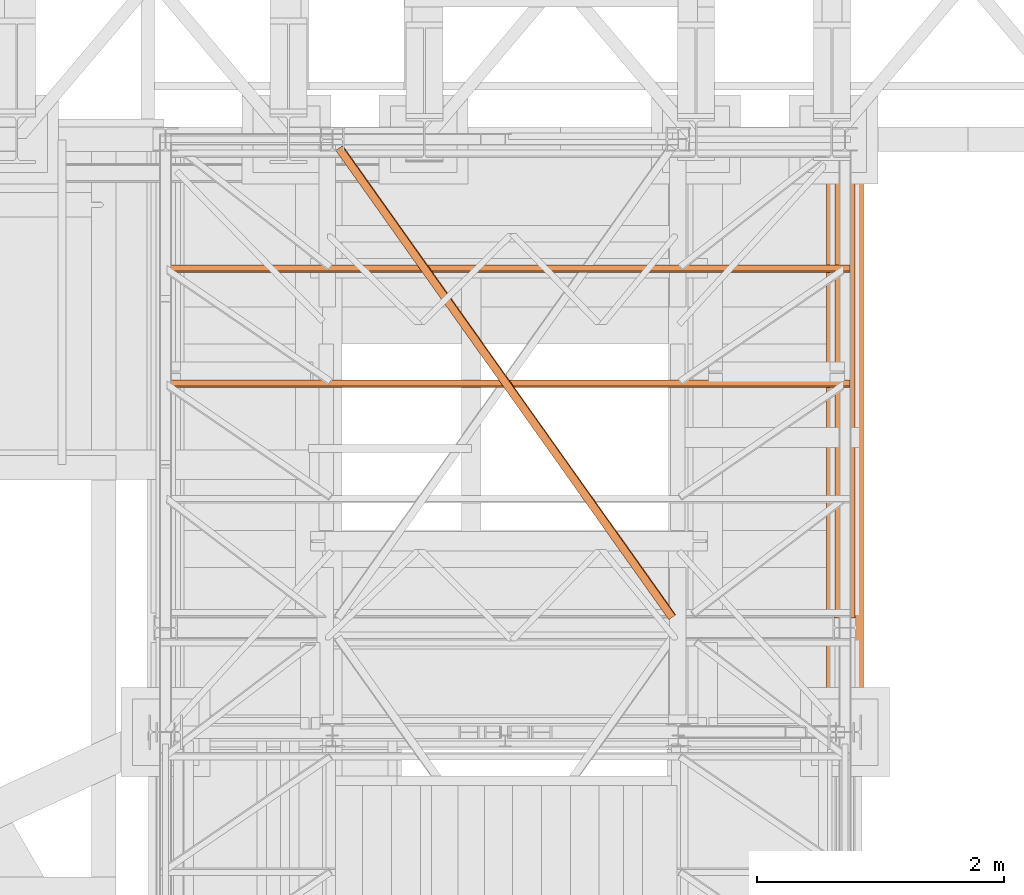
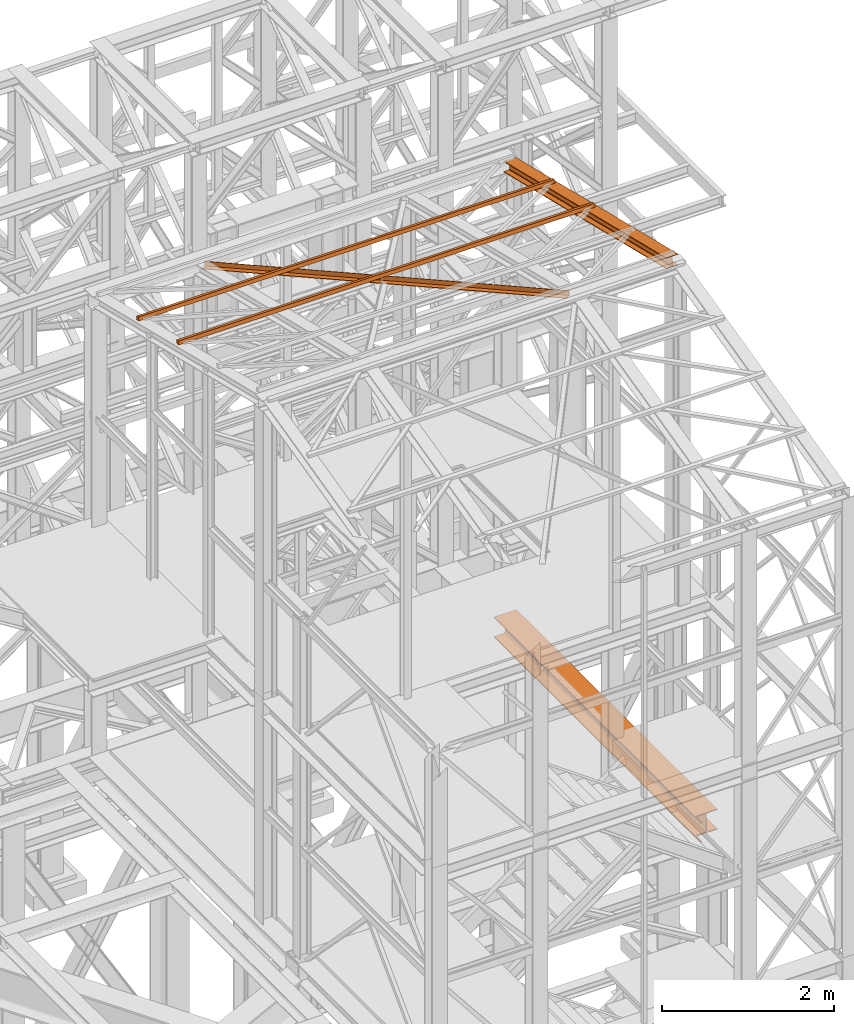
# One storey, part 67 of 208: 5 proxies.
"""IFC2X3 building model written with IfcOpenShell, lengths in millimetres."""

import ifcopenshell
import ifcopenshell.guid

model = None  # the IFC model being written
_history = None  # IfcOwnerHistory: only IFC2X3 demands one
_inside = {}  # id of a spatial element -> (the spatial element, [elements in it])
_under = {}  # id of a project, library or spatial element -> (it, [spatial elements below it])
_declared = {}  # id of a project -> (the project, [libraries it declares])
_typed = {}  # id of a type object -> (the type object, [elements of that type])
_made_of = {}  # id of a material, layer set ... -> (it, [elements and type objects made of it])


def new_model(schema):
    """Start an empty IFC model of exactly this schema.

    Asked for "IFC4X3", IfcOpenShell would pick the latest addendum, in which some entities
    have other attributes; the version numbers below select the first issue.
    IFC2X3 requires an IfcOwnerHistory on every rooted entity: one is made here for all.
    """
    global model, _history
    if schema == "IFC4X3":
        model = ifcopenshell.file(schema_version=(4, 3, 0, 0))
    else:
        model = ifcopenshell.file(schema=schema)
    _inside.clear()
    _under.clear()
    _declared.clear()
    _typed.clear()
    _made_of.clear()
    _history = None
    if model.schema == "IFC2X3":
        org = make("IfcOrganization", Name="unknown")
        user = make(
            "IfcPersonAndOrganization",
            ThePerson=make("IfcPerson", FamilyName="unknown"),
            TheOrganization=org,
        )
        app = make(
            "IfcApplication",
            ApplicationDeveloper=org,
            Version="unknown",
            ApplicationFullName="unknown",
            ApplicationIdentifier="unknown",
        )
        _history = make(
            "IfcOwnerHistory",
            OwningUser=user,
            OwningApplication=app,
            ChangeAction="ADDED",
            CreationDate=0,
        )
    return model


def make(cls, **values):
    """One entity of the class cls with the attributes given. An attribute that is None is left unset."""
    return model.create_entity(
        cls, **{name: value for name, value in values.items() if value is not None}
    )


def entity(cls, *values):
    """Any entity or typed value of the class cls, its attributes in the order of the schema. None: left unset."""
    e = model.create_entity(cls)
    for i, value in enumerate(values):
        if value is not None:
            e[i] = value
    return e


def rooted(cls, **values):
    """An entity with a GlobalId (a new one), such as an element, a storey or a relation."""
    return make(cls, GlobalId=ifcopenshell.guid.new(), OwnerHistory=_history, **values)


def si_unit(unit_type, name, prefix=None):
    """IfcSIUnit, for example si_unit("LENGTHUNIT", "METRE", prefix="MILLI")."""
    return make("IfcSIUnit", UnitType=unit_type, Prefix=prefix, Name=name)


def converted_unit(unit_type, name, factor, base, dimensions=None, offset=None):
    """IfcConversionBasedUnit, such as the inch: factor (a typed value) times the base unit."""
    return make(
        "IfcConversionBasedUnit"
        if offset is None
        else "IfcConversionBasedUnitWithOffset",
        ConversionOffset=offset,
        Dimensions=None
        if dimensions is None
        else entity("IfcDimensionalExponents", *dimensions),
        UnitType=unit_type,
        Name=name,
        ConversionFactor=make(
            "IfcMeasureWithUnit", ValueComponent=factor, UnitComponent=base
        ),
    )


def assignment(units):
    """IfcUnitAssignment: the units of a project."""
    return None if units is None else make("IfcUnitAssignment", Units=units)


def point(xyz):
    """IfcCartesianPoint."""
    return None if xyz is None else make("IfcCartesianPoint", Coordinates=xyz)


def direction(xyz):
    """IfcDirection."""
    return None if xyz is None else make("IfcDirection", DirectionRatios=xyz)


def frame(location, z_axis=None, x_axis=None):
    """IfcAxis2Placement3D, a coordinate frame: its origin and axes. An axis left out is left unset."""
    return make(
        "IfcAxis2Placement3D",
        Location=point(location),
        Axis=direction(z_axis),
        RefDirection=direction(x_axis),
    )


def origin():
    """The frame at (0, 0, 0) with its axes left unset."""
    return frame((0.0, 0.0, 0.0))


def origin_with_axes():
    """The frame at (0, 0, 0) with the z axis (0, 0, 1) and the x axis (1, 0, 0) written out."""
    return frame((0.0, 0.0, 0.0), z_axis=(0.0, 0.0, 1.0), x_axis=(1.0, 0.0, 0.0))


def place(relative_to, where):
    """IfcLocalPlacement: puts the frame where relative to a parent placement (None: the world)."""
    return make(
        "IfcLocalPlacement", PlacementRelTo=relative_to, RelativePlacement=where
    )


def context(
    kind, dimensions, precision=None, world=None, true_north=None, identifier=None
):
    """IfcGeometricRepresentationContext, for example the 3D "Model" context."""
    return make(
        "IfcGeometricRepresentationContext",
        ContextIdentifier=identifier,
        ContextType=kind,
        CoordinateSpaceDimension=dimensions,
        Precision=precision,
        WorldCoordinateSystem=world,
        TrueNorth=true_north,
    )


def subcontext(parent, identifier, kind, view, scale=None):
    """IfcGeometricRepresentationSubContext, for example "Body" below "Model"."""
    return make(
        "IfcGeometricRepresentationSubContext",
        ContextIdentifier=identifier,
        ContextType=kind,
        ParentContext=parent,
        TargetScale=scale,
        TargetView=view,
    )


def project(units=None, contexts=None):
    """IfcProject with its units and contexts."""
    return rooted(
        "IfcProject",
        Name="project",
        RepresentationContexts=contexts,
        UnitsInContext=assignment(units),
    )


def spatial(cls, under=None, at=None, **own):
    """A site, building, storey or space (cls), placed at a placement, below another one or the project."""
    s = rooted(cls, ObjectPlacement=at, **own)
    if under is not None:
        _under.setdefault(under.id(), (under, []))[1].append(s)
    return s


def faces_of(points, faces, orient=None, outer=None):
    """IfcFace entities. A face is a list of loops; a loop is a list of indices into points, from 0.

    orient and outer hold one flag for each loop. By default every Orientation is true, the
    first loop of a face is its IfcFaceOuterBound and the others are IfcFaceBound.
    """
    made = []
    for i, loops in enumerate(faces):
        bounds = []
        for j, loop in enumerate(loops):
            is_outer = j == 0 if outer is None else outer[i][j]
            bounds.append(
                make(
                    "IfcFaceOuterBound" if is_outer else "IfcFaceBound",
                    Bound=make("IfcPolyLoop", Polygon=[points[k] for k in loop]),
                    Orientation=True if orient is None else orient[i][j],
                )
            )
        made.append(make("IfcFace", Bounds=bounds))
    return made


def faceted_brep(points, faces, orient=None, outer=None, voids=None):
    """IfcFacetedBrep: a solid bounded by flat faces; with voids (closed shells), ...WithVoids."""
    shared = [point(p) for p in points]
    hull = make("IfcClosedShell", CfsFaces=faces_of(shared, faces, orient, outer))
    if voids is None:
        return make("IfcFacetedBrep", Outer=hull)
    return make(
        "IfcFacetedBrepWithVoids",
        Outer=hull,
        Voids=[
            make(cls, CfsFaces=faces_of(shared, fs, o, b)) for cls, fs, o, b in voids
        ],
    )


def shape(context_of_items, identifier, shape_type, items):
    """IfcShapeRepresentation: the items that make up one representation, for example the "Body"."""
    return make(
        "IfcShapeRepresentation",
        ContextOfItems=context_of_items,
        RepresentationIdentifier=identifier,
        RepresentationType=shape_type,
        Items=items,
    )


def made_of(thing, what):
    """Note that an element or type object is made of a material, layer set ...; save() writes the relation."""
    if what is not None:
        _made_of.setdefault(what.id(), (what, []))[1].append(thing)
    return thing


def element(
    cls,
    number,
    at=None,
    inside=None,
    cuts=None,
    type_object=None,
    material=None,
    context=None,
    identifier="Body",
    shape_type=None,
    held_by="IfcProductDefinitionShape",
    body=None,
    shapes=None,
    **own,
):
    """One element of the class cls, such as IfcWall. Its Tag is "e" and its number.

    at: its placement. inside: the storey or other place that contains it. cuts: it is an
    opening in that element (IfcRelVoidsElement). A single representation is given by context,
    identifier, shape_type and body (its items); several are given by shapes. held_by: the class
    of the entity that holds the representations. save() writes the other relations.
    """
    e = rooted(cls, Tag="e%d" % number, ObjectPlacement=at, **own)
    if body is not None:
        shapes = [shape(context, identifier, shape_type, body)]
    if shapes is not None:
        e.Representation = make(held_by, Representations=shapes)
    if inside is not None:
        _inside.setdefault(inside.id(), (inside, []))[1].append(e)
    if cuts is not None:
        rooted(
            "IfcRelVoidsElement", RelatingBuildingElement=cuts, RelatedOpeningElement=e
        )
    if type_object is not None:
        _typed.setdefault(type_object.id(), (type_object, []))[1].append(e)
    return made_of(e, material)


def aggregate(whole, parts):
    """IfcRelAggregates: a whole, such as a stair, and the parts it consists of."""
    return rooted("IfcRelAggregates", RelatingObject=whole, RelatedObjects=parts)


def save(model, path):
    """Write the relations noted so far, then the file.

    IfcRelAggregates (storeys below a building ...), IfcRelContainedInSpatialStructure (elements
    in a storey), IfcRelDefinesByType, IfcRelAssociatesMaterial and IfcRelDeclares: one each for
    every whole, place, type object, material and project.
    """
    for whole, parts in _under.values():
        aggregate(whole, parts)
    for where, things in _inside.values():
        rooted(
            "IfcRelContainedInSpatialStructure",
            RelatedElements=things,
            RelatingStructure=where,
        )
    for kind, things in _typed.values():
        rooted("IfcRelDefinesByType", RelatedObjects=things, RelatingType=kind)
    for what, things in _made_of.values():
        rooted("IfcRelAssociatesMaterial", RelatedObjects=things, RelatingMaterial=what)
    for by, libraries in _declared.values():
        rooted("IfcRelDeclares", RelatingContext=by, RelatedDefinitions=libraries)
    model.write(path)


model = new_model("IFC2X3")

# Units and contexts
model_context = context("Model", 3, precision=1e-05, world=origin())
plan_context = context("Plan", 3, precision=1e-05, world=origin())
body_context = subcontext(model_context, "Body", "Model", "MODEL_VIEW")
ifc_project = project(units=[si_unit("LENGTHUNIT", "METRE", prefix="MILLI"), converted_unit("PLANEANGLEUNIT", "DEGREE", entity("IfcPlaneAngleMeasure", 0.0174532925199433), si_unit("PLANEANGLEUNIT", "RADIAN"), dimensions=[0, 0, 0, 0, 0, 0, 0]), si_unit("AREAUNIT", "SQUARE_METRE"), si_unit("VOLUMEUNIT", "CUBIC_METRE")], contexts=[model_context, plan_context])

# Building, storey
building_placement = place(None, origin())
building = spatial("IfcBuilding", under=ifc_project, at=building_placement, CompositionType="COMPLEX")
storey_placement = place(building_placement, origin_with_axes())
storey = spatial("IfcBuildingStorey", under=building, at=storey_placement, Name="Geschoss", CompositionType="ELEMENT")

# Proxies
proxy_1_placement = place(storey_placement, frame((6548.254968528665, -22062.57439031789, 4994.990005364416), z_axis=(0.0, 0.0, 1.0), x_axis=(1.0, 0.0, 0.0)))
element("IfcBuildingElementProxy", 1, at=proxy_1_placement, inside=storey, context=body_context, shape_type="Brep", body=[
    faceted_brep([(300.0099999999993, 140.0100005960485, 290.0100000000002), (300.0100000000002, 4805.080528512532, 290.0100000000002), (300.0100000000002, 4805.080528512532, 276.0100000000002), (300.0099999999993, 140.0100005960485, 276.0100000000002), (300.0099999999993, 140.0100005960485, 276.0100000000002), (300.0100000000002, 4805.080528512532, 276.0100000000002), (181.2600000000002, 4805.080528512532, 276.0100000000002), (181.2600000000002, 140.0100005960485, 276.0100000000002), (181.2600000000002, 140.0100005960485, 276.0100000000002), (181.2600000000002, 4805.080528512532, 276.0100000000002), (172.9165694541389, 4805.080528512532, 274.6884339422595), (172.9165694541389, 140.0100005960485, 274.6884339422595), (172.9165694541389, 140.0100005960485, 274.6884339422595), (172.9165694541389, 4805.080528512532, 274.6884339422595), (165.3898249341983, 4805.080528512532, 270.8534254634033), (165.3898249341983, 140.0100005960485, 270.8534254634024), (165.3898249341983, 140.0100005960485, 270.8534254634024), (165.3898249341983, 4805.080528512532, 270.8534254634033), (159.4165745365972, 4805.080528512532, 264.8801750658022), (159.4165745365972, 140.0100005960485, 264.8801750658022), (159.4165745365972, 140.0100005960485, 264.8801750658022), (159.4165745365972, 4805.080528512532, 264.8801750658022), (155.5815660577391, 4805.080528512532, 257.3534305458616), (155.5815660577391, 140.0100005960485, 257.3534305458607), (155.5815660577391, 140.0100005960485, 257.3534305458607), (155.5815660577391, 4805.080528512532, 257.3534305458616), (154.2600000000002, 4805.080528512532, 249.0100000000002), (154.2600000000002, 140.0100005960485, 249.0100000000002), (154.2600000000002, 140.0100005960485, 249.0100000000002), (154.2600000000002, 4805.080528512532, 249.0100000000002), (154.2600000000002, 4805.080528512532, 41.01000000000022), (154.2600000000002, 140.0100005960485, 41.01000000000022), (154.2600000000002, 140.0100005960485, 41.01000000000022), (154.2600000000002, 4805.080528512532, 41.01000000000022), (155.5815660577391, 4805.080528512532, 32.6665694541407), (155.5815660577391, 140.0100005960485, 32.66656945413979), (155.5815660577391, 140.0100005960485, 32.66656945413979), (155.5815660577391, 4805.080528512532, 32.6665694541407), (159.4165745365972, 4805.080528512532, 25.13982493419917), (159.4165745365972, 140.0100005960485, 25.13982493419826), (159.4165745365972, 140.0100005960485, 25.13982493419826), (159.4165745365972, 4805.080528512532, 25.13982493419917), (165.3898249341983, 4805.080528512532, 19.166574536599), (165.3898249341983, 140.0100005960485, 19.16657453659809), (165.3898249341983, 140.0100005960485, 19.16657453659809), (165.3898249341983, 4805.080528512532, 19.166574536599), (172.9165694541389, 4805.080528512532, 15.33156605774093), (172.9165694541389, 140.0100005960485, 15.33156605774093), (172.9165694541389, 140.0100005960485, 15.33156605774093), (172.9165694541389, 4805.080528512532, 15.33156605774093), (181.2600000000002, 4805.080528512532, 14.01000000000022), (181.2600000000002, 140.0100005960485, 14.01000000000022), (181.2600000000002, 140.0100005960485, 14.01000000000022), (181.2600000000002, 4805.080528512532, 14.01000000000022), (300.0100000000002, 4805.080528512532, 14.01000000000022), (300.0099999999993, 140.0100005960485, 14.01000000000022), (300.0099999999993, 140.0100005960485, 14.01000000000022), (300.0100000000002, 4805.080528512532, 14.01000000000022), (300.0100000000002, 4805.080528512532, 0.01000000000021828), (300.0099999999993, 140.0100005960485, 0.01000000000021828), (300.0099999999993, 140.0100005960485, 0.01000000000021828), (300.0100000000002, 4805.080528512532, 0.01000000000021828), (0.01000000000021828, 4805.080528512532, 0.01000000000021828), (0.01000000000021828, 0.01000000000203727, 0.01000000000021828), (15.00999463558401, 0.01000000000203727, 0.01000000000021828), (15.00999463558401, 140.0100005960485, 0.01000000000021828), (0.01000000000021828, 0.01000000000203727, 0.01000000000021828), (0.01000000000021828, 4805.080528512532, 0.01000000000021828), (0.01000000000021828, 4805.080528512532, 14.01000000000022), (0.01000000000021828, 0.01000000000203727, 14.01000000000022), (0.01000000000021828, 0.01000000000203727, 14.01000000000022), (0.01000000000021828, 4805.080528512532, 14.01000000000022), (118.7600000000002, 4805.080528512532, 14.01000000000022), (118.7600000000002, 140.0100005960485, 14.01000000000022), (15.00999463558401, 140.0100005960485, 14.01000000000022), (15.00999463558401, 0.01000000000203727, 14.01000000000022), (118.7600000000002, 140.0100005960485, 14.01000000000022), (118.7600000000002, 4805.080528512532, 14.01000000000022), (127.1034305458597, 4805.080528512532, 15.33156605774093), (127.1034305458597, 140.0100005960485, 15.33156605774093), (127.1034305458597, 140.0100005960485, 15.33156605774093), (127.1034305458597, 4805.080528512532, 15.33156605774093), (134.6301750658004, 4805.080528512532, 19.166574536599), (134.6301750658004, 140.0100005960485, 19.16657453659809), (134.6301750658004, 140.0100005960485, 19.16657453659809), (134.6301750658004, 4805.080528512532, 19.166574536599), (140.6034254634014, 4805.080528512532, 25.13982493419917), (140.6034254634014, 140.0100005960485, 25.13982493419826), (140.6034254634014, 140.0100005960485, 25.13982493419826), (140.6034254634014, 4805.080528512532, 25.13982493419917), (144.4384339422595, 4805.080528512532, 32.6665694541407), (144.4384339422595, 140.0100005960485, 32.66656945413979), (144.4384339422595, 140.0100005960485, 32.66656945413979), (144.4384339422595, 4805.080528512532, 32.6665694541407), (145.7600000000002, 4805.080528512532, 41.01000000000022), (145.7600000000002, 140.0100005960485, 41.01000000000022), (145.7600000000002, 140.0100005960485, 41.01000000000022), (145.7600000000002, 4805.080528512532, 41.01000000000022), (145.7600000000002, 4805.080528512532, 249.0100000000002), (145.7600000000002, 140.0100005960485, 249.0100000000002), (145.7600000000002, 140.0100005960485, 249.0100000000002), (145.7600000000002, 4805.080528512532, 249.0100000000002), (144.4384339422595, 4805.080528512532, 257.3534305458616), (144.4384339422595, 140.0100005960485, 257.3534305458607), (144.4384339422595, 140.0100005960485, 257.3534305458607), (144.4384339422595, 4805.080528512532, 257.3534305458616), (140.6034254634014, 4805.080528512532, 264.8801750658022), (140.6034254634014, 140.0100005960485, 264.8801750658022), (140.6034254634014, 140.0100005960485, 264.8801750658022), (140.6034254634014, 4805.080528512532, 264.8801750658022), (134.6301750658004, 4805.080528512532, 270.8534254634033), (134.6301750658004, 140.0100005960485, 270.8534254634024), (134.6301750658004, 140.0100005960485, 270.8534254634024), (134.6301750658004, 4805.080528512532, 270.8534254634033), (127.1034305458597, 4805.080528512532, 274.6884339422595), (127.1034305458597, 140.0100005960485, 274.6884339422595), (127.1034305458597, 140.0100005960485, 274.6884339422595), (127.1034305458597, 4805.080528512532, 274.6884339422595), (118.7600000000002, 4805.080528512532, 276.0100000000002), (118.7600000000002, 140.0100005960485, 276.0100000000002), (118.7600000000002, 140.0100005960485, 276.0100000000002), (118.7600000000002, 4805.080528512532, 276.0100000000002), (0.01000000000021828, 4805.080528512532, 276.0100000000002), (0.01000000000021828, 0.01000000000203727, 276.0100000000002), (15.00999463558401, 0.01000000000203727, 276.0100000000002), (15.00999463558401, 140.0100005960485, 276.0100000000002), (0.01000000000021828, 0.01000000000203727, 276.0100000000002), (0.01000000000021828, 4805.080528512532, 276.0100000000002), (0.01000000000021828, 4805.080528512532, 290.0100000000002), (0.01000000000021828, 0.01000000000203727, 290.0100000000002), (0.01000000000021828, 0.01000000000203727, 290.0100000000002), (0.01000000000021828, 4805.080528512532, 290.0100000000002), (300.0100000000002, 4805.080528512532, 290.0100000000002), (300.0099999999993, 140.0100005960485, 290.0100000000002), (15.00999463558401, 140.0100005960485, 290.0100000000002), (15.00999463558401, 0.01000000000203727, 290.0100000000002), (300.0099999999993, 140.0100005960485, 290.0100000000002), (300.0099999999993, 140.0100005960485, 276.0100000000002), (181.2600000000002, 140.0100005960485, 276.0100000000002), (172.9165694541389, 140.0100005960485, 274.6884339422595), (165.3898249341983, 140.0100005960485, 270.8534254634024), (159.4165745365972, 140.0100005960485, 264.8801750658022), (155.5815660577391, 140.0100005960485, 257.3534305458607), (154.2600000000002, 140.0100005960485, 249.0100000000002), (154.2600000000002, 140.0100005960485, 41.01000000000022), (155.5815660577391, 140.0100005960485, 32.66656945413979), (159.4165745365972, 140.0100005960485, 25.13982493419826), (165.3898249341983, 140.0100005960485, 19.16657453659809), (172.9165694541389, 140.0100005960485, 15.33156605774093), (181.2600000000002, 140.0100005960485, 14.01000000000022), (300.0099999999993, 140.0100005960485, 14.01000000000022), (300.0099999999993, 140.0100005960485, 0.01000000000021828), (15.00999463558401, 140.0100005960485, 0.01000000000021828), (15.00999463558401, 140.0100005960485, 14.01000000000022), (118.7600000000002, 140.0100005960485, 14.01000000000022), (127.1034305458597, 140.0100005960485, 15.33156605774093), (134.6301750658004, 140.0100005960485, 19.16657453659809), (140.6034254634014, 140.0100005960485, 25.13982493419826), (144.4384339422595, 140.0100005960485, 32.66656945413979), (145.7600000000002, 140.0100005960485, 41.01000000000022), (145.7600000000002, 140.0100005960485, 249.0100000000002), (144.4384339422595, 140.0100005960485, 257.3534305458607), (140.6034254634014, 140.0100005960485, 264.8801750658022), (134.6301750658004, 140.0100005960485, 270.8534254634024), (127.1034305458597, 140.0100005960485, 274.6884339422595), (118.7600000000002, 140.0100005960485, 276.0100000000002), (15.00999463558401, 140.0100005960485, 276.0100000000002), (15.00999463558401, 140.0100005960485, 290.0100000000002), (15.00999463558401, 0.01000000000203727, 14.01000000000022), (15.00999463558401, 0.01000000000203727, 0.01000000000021828), (0.01000000000021828, 0.01000000000203727, 0.01000000000021828), (0.01000000000021828, 0.01000000000203727, 14.01000000000022), (15.00999463558401, 0.01000000000203727, 276.0100000000002), (0.01000000000021828, 0.01000000000203727, 276.0100000000002), (0.01000000000021828, 0.01000000000203727, 290.0100000000002), (15.00999463558401, 0.01000000000203727, 290.0100000000002), (300.0100000000002, 4805.080528512532, 290.0100000000002), (0.01000000000021828, 4805.080528512532, 290.0100000000002), (0.01000000000021828, 4805.080528512532, 276.0100000000002), (118.7600000000002, 4805.080528512532, 276.0100000000002), (127.1034305458597, 4805.080528512532, 274.6884339422595), (134.6301750658004, 4805.080528512532, 270.8534254634033), (140.6034254634014, 4805.080528512532, 264.8801750658022), (144.4384339422595, 4805.080528512532, 257.3534305458616), (145.7600000000002, 4805.080528512532, 249.0100000000002), (145.7600000000002, 4805.080528512532, 41.01000000000022), (144.4384339422595, 4805.080528512532, 32.6665694541407), (140.6034254634014, 4805.080528512532, 25.13982493419917), (134.6301750658004, 4805.080528512532, 19.166574536599), (127.1034305458597, 4805.080528512532, 15.33156605774093), (118.7600000000002, 4805.080528512532, 14.01000000000022), (0.01000000000021828, 4805.080528512532, 14.01000000000022), (0.01000000000021828, 4805.080528512532, 0.01000000000021828), (300.0100000000002, 4805.080528512532, 0.01000000000021828), (300.0100000000002, 4805.080528512532, 14.01000000000022), (181.2600000000002, 4805.080528512532, 14.01000000000022), (172.9165694541389, 4805.080528512532, 15.33156605774093), (165.3898249341983, 4805.080528512532, 19.166574536599), (159.4165745365972, 4805.080528512532, 25.13982493419917), (155.5815660577391, 4805.080528512532, 32.6665694541407), (154.2600000000002, 4805.080528512532, 41.01000000000022), (154.2600000000002, 4805.080528512532, 249.0100000000002), (155.5815660577391, 4805.080528512532, 257.3534305458616), (159.4165745365972, 4805.080528512532, 264.8801750658022), (165.3898249341983, 4805.080528512532, 270.8534254634033), (172.9165694541389, 4805.080528512532, 274.6884339422595), (181.2600000000002, 4805.080528512532, 276.0100000000002), (300.0100000000002, 4805.080528512532, 276.0100000000002), (15.00999463558401, 140.0100005960485, 0.01000000000021828), (15.00999463558401, 0.01000000000203727, 0.01000000000021828), (15.00999463558401, 0.01000000000203727, 14.01000000000022), (15.00999463558401, 140.0100005960485, 14.01000000000022), (15.00999463558401, 140.0100005960485, 276.0100000000002), (15.00999463558401, 0.01000000000203727, 276.0100000000002), (15.00999463558401, 0.01000000000203727, 290.0100000000002), (15.00999463558401, 140.0100005960485, 290.0100000000002)], [[[0, 1, 2, 3]], [[4, 5, 6, 7]], [[8, 9, 10, 11]], [[12, 13, 14, 15]], [[16, 17, 18, 19]], [[20, 21, 22, 23]], [[24, 25, 26, 27]], [[28, 29, 30, 31]], [[32, 33, 34, 35]], [[36, 37, 38, 39]], [[40, 41, 42, 43]], [[44, 45, 46, 47]], [[48, 49, 50, 51]], [[52, 53, 54, 55]], [[56, 57, 58, 59]], [[60, 61, 62, 63, 64, 65]], [[66, 67, 68, 69]], [[70, 71, 72, 73, 74, 75]], [[76, 77, 78, 79]], [[80, 81, 82, 83]], [[84, 85, 86, 87]], [[88, 89, 90, 91]], [[92, 93, 94, 95]], [[96, 97, 98, 99]], [[100, 101, 102, 103]], [[104, 105, 106, 107]], [[108, 109, 110, 111]], [[112, 113, 114, 115]], [[116, 117, 118, 119]], [[120, 121, 122, 123, 124, 125]], [[126, 127, 128, 129]], [[130, 131, 132, 133, 134, 135]], [[136, 137, 138, 139, 140, 141, 142, 143, 144, 145, 146, 147, 148, 149, 150, 151, 152, 153, 154, 155, 156, 157, 158, 159, 160, 161, 162, 163, 164, 165, 166, 167]], [[168, 169, 170, 171]], [[172, 173, 174, 175]], [[176, 177, 178, 179, 180, 181, 182, 183, 184, 185, 186, 187, 188, 189, 190, 191, 192, 193, 194, 195, 196, 197, 198, 199, 200, 201, 202, 203, 204, 205, 206, 207]], [[208, 209, 210, 211]], [[212, 213, 214, 215]]], orient=[[False], [False], [False], [False], [False], [False], [False], [False], [False], [False], [False], [False], [False], [False], [False], [False], [False], [False], [False], [False], [False], [False], [False], [False], [False], [False], [False], [False], [False], [False], [False], [False], [False], [False], [False], [False], [False], [False]]),
])
proxy_2_placement = place(storey_placement, frame((1157.254971121463, -19272.89991602248, 12238.48670466169), z_axis=(0.0, 0.0, 1.0), x_axis=(1.0, 0.0, 0.0)))
element("IfcBuildingElementProxy", 2, at=proxy_2_placement, inside=storey, context=body_context, shape_type="Brep", body=[
    faceted_brep([(5582.010002264973, 11.80406569683692, 60.39315927079588), (5582.010002264973, 60.39315927079224, 48.59909357395736), (5582.010002264973, 48.59909357395372, 0.01000000000021828), (5582.010002264973, 0.00999999999839929, 11.80406569683873), (0.01000000000021828, 60.39315927079224, 48.59909357395736), (0.01000000000021828, 11.80406569683692, 60.39315927079588), (0.01000000000021828, 0.00999999999839929, 11.80406569683873), (0.01000000000021828, 48.59909357395372, 0.01000000000021828), (5582.010002264973, 60.39315927079224, 48.59909357395736), (5582.010002264973, 11.80406569683692, 60.39315927079588), (0.01000000000021828, 11.80406569683692, 60.39315927079588), (0.01000000000021828, 60.39315927079224, 48.59909357395736), (5582.010002264973, 48.59909357395372, 0.01000000000021828), (5582.010002264973, 60.39315927079224, 48.59909357395736), (0.01000000000021828, 60.39315927079224, 48.59909357395736), (0.01000000000021828, 48.59909357395372, 0.01000000000021828), (5582.010002264973, 0.00999999999839929, 11.80406569683873), (5582.010002264973, 48.59909357395372, 0.01000000000021828), (0.01000000000021828, 48.59909357395372, 0.01000000000021828), (0.01000000000021828, 0.00999999999839929, 11.80406569683873), (5582.010002264973, 11.80406569683692, 60.39315927079588), (5582.010002264973, 0.00999999999839929, 11.80406569683873), (0.01000000000021828, 0.00999999999839929, 11.80406569683873), (0.01000000000021828, 11.80406569683692, 60.39315927079588)], [[[0, 1, 2, 3]], [[4, 5, 6, 7]], [[8, 9, 10, 11]], [[12, 13, 14, 15]], [[16, 17, 18, 19]], [[20, 21, 22, 23]]], orient=[[False], [False], [False], [False], [False], [False]]),
])
proxy_3_placement = place(storey_placement, frame((1157.254971121463, -18340.85992356571, 12012.25196565828), z_axis=(0.0, 0.0, 1.0), x_axis=(1.0, 0.0, 0.0)))
element("IfcBuildingElementProxy", 3, at=proxy_3_placement, inside=storey, context=body_context, shape_type="Brep", body=[
    faceted_brep([(5582.010002264973, 11.80406569683692, 60.39315927079406), (5582.010002264973, 60.39315927079224, 48.59909357395554), (5582.010002264973, 48.59909357395372, 0.00999999999839929), (5582.010002264973, 0.00999999999839929, 11.80406569683692), (0.01000000000021828, 60.39315927079224, 48.59909357395554), (0.01000000000021828, 11.80406569683692, 60.39315927079406), (0.01000000000021828, 0.00999999999839929, 11.80406569683692), (0.01000000000021828, 48.59909357395372, 0.00999999999839929), (5582.010002264973, 60.39315927079224, 48.59909357395554), (5582.010002264973, 11.80406569683692, 60.39315927079406), (0.01000000000021828, 11.80406569683692, 60.39315927079406), (0.01000000000021828, 60.39315927079224, 48.59909357395554), (5582.010002264973, 48.59909357395372, 0.00999999999839929), (5582.010002264973, 60.39315927079224, 48.59909357395554), (0.01000000000021828, 60.39315927079224, 48.59909357395554), (0.01000000000021828, 48.59909357395372, 0.00999999999839929), (5582.010002264973, 0.00999999999839929, 11.80406569683692), (5582.010002264973, 48.59909357395372, 0.00999999999839929), (0.01000000000021828, 48.59909357395372, 0.00999999999839929), (0.01000000000021828, 0.00999999999839929, 11.80406569683692), (5582.010002264973, 11.80406569683692, 60.39315927079406), (5582.010002264973, 0.00999999999839929, 11.80406569683692), (0.01000000000021828, 0.00999999999839929, 11.80406569683692), (0.01000000000021828, 11.80406569683692, 60.39315927079406)], [[[0, 1, 2, 3]], [[4, 5, 6, 7]], [[8, 9, 10, 11]], [[12, 13, 14, 15]], [[16, 17, 18, 19]], [[20, 21, 22, 23]]], orient=[[False], [False], [False], [False], [False], [False]]),
])
proxy_4_placement = place(storey_placement, frame((2575.615457417551, -21152.65208618946, 11664.17632924608), z_axis=(0.0, 0.0, 1.0), x_axis=(1.0, 0.0, 0.0)))
element("IfcBuildingElementProxy", 4, at=proxy_4_placement, inside=storey, context=body_context, shape_type="Brep", body=[
    faceted_brep([(2749.239290258734, 35.97350782090143, 950.2007534895147), (51.74027987850059, 3836.040656143225, 7.275807760785028), (51.74111174156951, 3836.041234464356, 71.5525025697425), (2749.240122121804, 35.97408614203232, 1014.47744829847), (2749.240122121804, 35.97408614203232, 1014.47744829847), (51.74111174156951, 3836.041234464356, 71.5525025697425), (57.48891034704411, 3840.037172638022, 71.56627510107865), (2754.987920727279, 39.97002431569854, 1014.491220829807), (2754.987920727279, 39.97002431569854, 1014.491220829807), (57.48891034704411, 3840.037172638022, 71.56627510107865), (57.48798605474622, 3840.036530058987, 0.1477253133507475), (2754.98699643498, 39.96938173666422, 943.0726710420768), (2754.98699643498, 39.96938173666422, 943.0726710420768), (57.48798605474622, 3840.036530058987, 0.1477253133507475), (0.01000000000021828, 3800.077148322325, 0.01000000000021828), (2697.509010380236, 0.01000000000203727, 942.934945728728), (2697.509010380236, 0.01000000000203727, 942.934945728728), (0.01000000000021828, 3800.077148322325, 0.01000000000021828), (0.01009242922918929, 3800.077212580232, 7.151854978770643), (2697.509102809469, 0.0100642579018313, 950.0768007075021), (2697.509102809469, 0.0100642579018313, 950.0768007075021), (0.01009242922918929, 3800.077212580232, 7.151854978770643), (51.74027987850059, 3836.040656143225, 7.275807760785028), (2749.239290258734, 35.97350782090143, 950.2007534895147), (2749.240122121804, 35.97408614203232, 1014.47744829847), (2754.987920727279, 39.97002431569854, 1014.491220829807), (2754.98699643498, 39.96938173666422, 943.0726710420768), (2697.509010380236, 0.01000000000203727, 942.934945728728), (2697.509102809469, 0.0100642579018313, 950.0768007075021), (2749.239290258734, 35.97350782090143, 950.2007534895147), (51.74027987850059, 3836.040656143225, 7.275807760785028), (0.01009242922918929, 3800.077212580232, 7.151854978770643), (0.01000000000021828, 3800.077148322325, 0.01000000000021828), (57.48798605474622, 3840.036530058987, 0.1477253133507475), (57.48891034704411, 3840.037172638022, 71.56627510107865), (51.74111174156951, 3836.041234464356, 71.5525025697425)], [[[0, 1, 2, 3]], [[4, 5, 6, 7]], [[8, 9, 10, 11]], [[12, 13, 14, 15]], [[16, 17, 18, 19]], [[20, 21, 22, 23]], [[24, 25, 26, 27, 28, 29]], [[30, 31, 32, 33, 34, 35]]], orient=[[False], [False], [False], [False], [False], [False], [False], [False]]),
])
proxy_5_placement = place(storey_placement, frame((6618.254966591513, -21137.57438465545, 11628.70515179705), z_axis=(0.0, 0.0, 1.0), x_axis=(1.0, 0.0, 0.0)))
element("IfcBuildingElementProxy", 5, at=proxy_5_placement, inside=storey, context=body_context, shape_type="Brep", body=[
    faceted_brep([(160.0100113248891, 0.01000000000203727, 1074.775244917653), (0.01000000000658474, 0.01000000000203727, 1074.775244917653), (0.01000000000021828, 3780.009979404025, 156.4315054631916), (160.01001132488, 3780.009979404025, 156.4315054631916), (0.01000000000658474, 0.01000000000203727, 1074.775244917653), (0.01000000000658474, 0.01000000000203727, 1065.513442427271), (0.01000000000021828, 3780.009979404025, 147.1697029728093), (0.01000000000021828, 3780.009979404025, 156.4315054631916), (0.01000000000658474, 0.01000000000203727, 1065.513442427271), (62.01000457466216, 0.01000000000203727, 1065.513442427271), (62.01000457465671, 3780.009979404025, 147.1697029728093), (0.01000000000021828, 3780.009979404025, 147.1697029728093), (62.01000457466216, 0.01000000000203727, 1065.513442427271), (69.77318079978795, 0.01000000000203727, 1063.914455819968), (69.77318079977886, 3780.009979404025, 145.5707163655079), (62.01000457465671, 3780.009979404025, 147.1697029728093), (69.77318079978795, 0.01000000000203727, 1063.914455819968), (75.45621545822087, 0.01000000000203727, 1058.066108594254), (75.45621545821086, 3780.009979404025, 139.7223691397903), (69.77318079977886, 3780.009979404025, 145.5707163655079), (75.45621545822087, 0.01000000000203727, 1058.066108594254), (77.0100056363699, 0.01000000000203727, 1050.077113888498), (77.0100056363608, 3780.009979404025, 131.7333744340358), (75.45621545821086, 3780.009979404025, 139.7223691397903), (77.0100056363699, 0.01000000000203727, 1050.077113888498), (77.0100056363699, 0.01000000000203727, 943.0518743172743), (77.0100056363608, 3780.009979404025, 24.70813486281259), (77.0100056363608, 3780.009979404025, 131.7333744340358), (77.0100056363699, 0.01000000000203727, 943.0518743172743), (75.45621545821996, 0.01000000000203727, 935.0628757778613), (75.45621545821086, 3780.009979404025, 16.71913632339965), (77.0100056363608, 3780.009979404025, 24.70813486281259), (75.45621545821996, 0.01000000000203727, 935.0628757778613), (69.77318079978795, 0.01000000000203727, 929.2145285521474), (69.77318079977886, 3780.009979404025, 10.87078909768752), (75.45621545821086, 3780.009979404025, 16.71913632339965), (69.77318079978795, 0.01000000000203727, 929.2145285521474), (62.01000457466216, 0.01000000000203727, 927.6155419448442), (62.01000457465307, 3780.009979404025, 9.27180249038247), (69.77318079977886, 3780.009979404025, 10.87078909768752), (62.01000457466216, 0.01000000000203727, 927.6155419448442), (0.01000000000658474, 0.01000000000203727, 927.6155419448423), (0.01000000000021828, 3780.009979404025, 9.27180249038247), (62.01000457465307, 3780.009979404025, 9.27180249038247), (0.01000000000658474, 0.01000000000203727, 927.6155419448423), (0.01000000000567525, 0.01000000000203727, 918.3537394544601), (0.01000000000021828, 3780.009979404025, 0.01000000000021828), (0.01000000000021828, 3780.009979404025, 9.27180249038247), (0.01000000000567525, 0.01000000000203727, 918.3537394544601), (160.0100113248891, 0.01000000000203727, 918.3537394544619), (160.0100113248827, 3780.009979404025, 0.01000000000021828), (0.01000000000021828, 3780.009979404025, 0.01000000000021828), (160.0100113248891, 0.01000000000203727, 918.3537394544619), (160.0100113248891, 0.01000000000203727, 927.6155419448423), (160.0100113248836, 3780.009979404025, 9.27180249038065), (160.0100113248827, 3780.009979404025, 0.01000000000021828), (160.0100113248891, 0.01000000000203727, 927.6155419448423), (98.0100067502317, 0.01000000000203727, 927.6155419448423), (98.0100067502226, 3780.009979404025, 9.27180249038247), (160.0100113248836, 3780.009979404025, 9.27180249038065), (98.0100067502317, 0.01000000000203727, 927.6155419448423), (90.2468305251059, 0.01000000000203727, 929.2145285521474), (90.24683052509681, 3780.009979404025, 10.87078909768752), (98.0100067502226, 3780.009979404025, 9.27180249038247), (90.2468305251059, 0.01000000000203727, 929.2145285521474), (84.5637958666739, 0.01000000000203727, 935.0628757778613), (84.5637958666648, 3780.009979404025, 16.71913632339783), (90.24683052509681, 3780.009979404025, 10.87078909768752), (84.5637958666739, 0.01000000000203727, 935.0628757778613), (83.01000568852396, 0.01000000000203727, 943.0518743172743), (83.01000568851487, 3780.009979404025, 24.70813486281077), (84.5637958666648, 3780.009979404025, 16.71913632339783), (83.01000568852396, 0.01000000000203727, 943.0518743172743), (83.01000568852396, 0.01000000000203727, 1050.077113888496), (83.01000568851578, 3780.009979404025, 131.733374434034), (83.01000568851487, 3780.009979404025, 24.70813486281077), (83.01000568852396, 0.01000000000203727, 1050.077113888496), (84.56379586667481, 0.01000000000203727, 1058.066108594254), (84.5637958666648, 3780.009979404025, 139.7223691397903), (83.01000568851578, 3780.009979404025, 131.733374434034), (84.56379586667481, 0.01000000000203727, 1058.066108594254), (90.24683052510682, 0.01000000000203727, 1063.914455819968), (90.24683052509772, 3780.009979404025, 145.5707163655079), (84.5637958666648, 3780.009979404025, 139.7223691397903), (90.24683052510682, 0.01000000000203727, 1063.914455819968), (98.0100067502317, 0.01000000000203727, 1065.513442427271), (98.0100067502226, 3780.009979404025, 147.1697029728093), (90.24683052509772, 3780.009979404025, 145.5707163655079), (98.0100067502317, 0.01000000000203727, 1065.513442427271), (160.0100113248891, 0.01000000000203727, 1065.513442427271), (160.0100113248836, 3780.009979404025, 147.1697029728093), (98.0100067502226, 3780.009979404025, 147.1697029728093), (160.0100113248891, 0.01000000000203727, 1065.513442427271), (160.0100113248891, 0.01000000000203727, 1074.775244917653), (160.01001132488, 3780.009979404025, 156.4315054631916), (160.0100113248836, 3780.009979404025, 147.1697029728093), (0.01000000000658474, 0.01000000000203727, 1074.775244917653), (160.0100113248891, 0.01000000000203727, 1074.775244917653), (160.0100113248891, 0.01000000000203727, 1065.513442427271), (98.0100067502317, 0.01000000000203727, 1065.513442427271), (90.24683052510682, 0.01000000000203727, 1063.914455819968), (84.56379586667481, 0.01000000000203727, 1058.066108594254), (83.01000568852396, 0.01000000000203727, 1050.077113888496), (83.01000568852396, 0.01000000000203727, 943.0518743172743), (84.5637958666739, 0.01000000000203727, 935.0628757778613), (90.2468305251059, 0.01000000000203727, 929.2145285521474), (98.0100067502317, 0.01000000000203727, 927.6155419448423), (160.0100113248891, 0.01000000000203727, 927.6155419448423), (160.0100113248891, 0.01000000000203727, 918.3537394544619), (0.01000000000567525, 0.01000000000203727, 918.3537394544601), (0.01000000000658474, 0.01000000000203727, 927.6155419448423), (62.01000457466216, 0.01000000000203727, 927.6155419448442), (69.77318079978795, 0.01000000000203727, 929.2145285521474), (75.45621545821996, 0.01000000000203727, 935.0628757778613), (77.0100056363699, 0.01000000000203727, 943.0518743172743), (77.0100056363699, 0.01000000000203727, 1050.077113888498), (75.45621545822087, 0.01000000000203727, 1058.066108594254), (69.77318079978795, 0.01000000000203727, 1063.914455819968), (62.01000457466216, 0.01000000000203727, 1065.513442427271), (0.01000000000658474, 0.01000000000203727, 1065.513442427271), (160.01001132488, 3780.009979404025, 156.4315054631916), (0.01000000000021828, 3780.009979404025, 156.4315054631916), (0.01000000000021828, 3780.009979404025, 147.1697029728093), (62.01000457465671, 3780.009979404025, 147.1697029728093), (69.77318079977886, 3780.009979404025, 145.5707163655079), (75.45621545821086, 3780.009979404025, 139.7223691397903), (77.0100056363608, 3780.009979404025, 131.7333744340358), (77.0100056363608, 3780.009979404025, 24.70813486281259), (75.45621545821086, 3780.009979404025, 16.71913632339965), (69.77318079977886, 3780.009979404025, 10.87078909768752), (62.01000457465307, 3780.009979404025, 9.27180249038247), (0.01000000000021828, 3780.009979404025, 9.27180249038247), (0.01000000000021828, 3780.009979404025, 0.01000000000021828), (160.0100113248827, 3780.009979404025, 0.01000000000021828), (160.0100113248836, 3780.009979404025, 9.27180249038065), (98.0100067502226, 3780.009979404025, 9.27180249038247), (90.24683052509681, 3780.009979404025, 10.87078909768752), (84.5637958666648, 3780.009979404025, 16.71913632339783), (83.01000568851487, 3780.009979404025, 24.70813486281077), (83.01000568851578, 3780.009979404025, 131.733374434034), (84.5637958666648, 3780.009979404025, 139.7223691397903), (90.24683052509772, 3780.009979404025, 145.5707163655079), (98.0100067502226, 3780.009979404025, 147.1697029728093), (160.0100113248836, 3780.009979404025, 147.1697029728093)], [[[0, 1, 2, 3]], [[4, 5, 6, 7]], [[8, 9, 10, 11]], [[12, 13, 14, 15]], [[16, 17, 18, 19]], [[20, 21, 22, 23]], [[24, 25, 26, 27]], [[28, 29, 30, 31]], [[32, 33, 34, 35]], [[36, 37, 38, 39]], [[40, 41, 42, 43]], [[44, 45, 46, 47]], [[48, 49, 50, 51]], [[52, 53, 54, 55]], [[56, 57, 58, 59]], [[60, 61, 62, 63]], [[64, 65, 66, 67]], [[68, 69, 70, 71]], [[72, 73, 74, 75]], [[76, 77, 78, 79]], [[80, 81, 82, 83]], [[84, 85, 86, 87]], [[88, 89, 90, 91]], [[92, 93, 94, 95]], [[96, 97, 98, 99, 100, 101, 102, 103, 104, 105, 106, 107, 108, 109, 110, 111, 112, 113, 114, 115, 116, 117, 118, 119]], [[120, 121, 122, 123, 124, 125, 126, 127, 128, 129, 130, 131, 132, 133, 134, 135, 136, 137, 138, 139, 140, 141, 142, 143]]], orient=[[False], [False], [False], [False], [False], [False], [False], [False], [False], [False], [False], [False], [False], [False], [False], [False], [False], [False], [False], [False], [False], [False], [False], [False], [False], [False]]),
])

save(model, "model.ifc")
